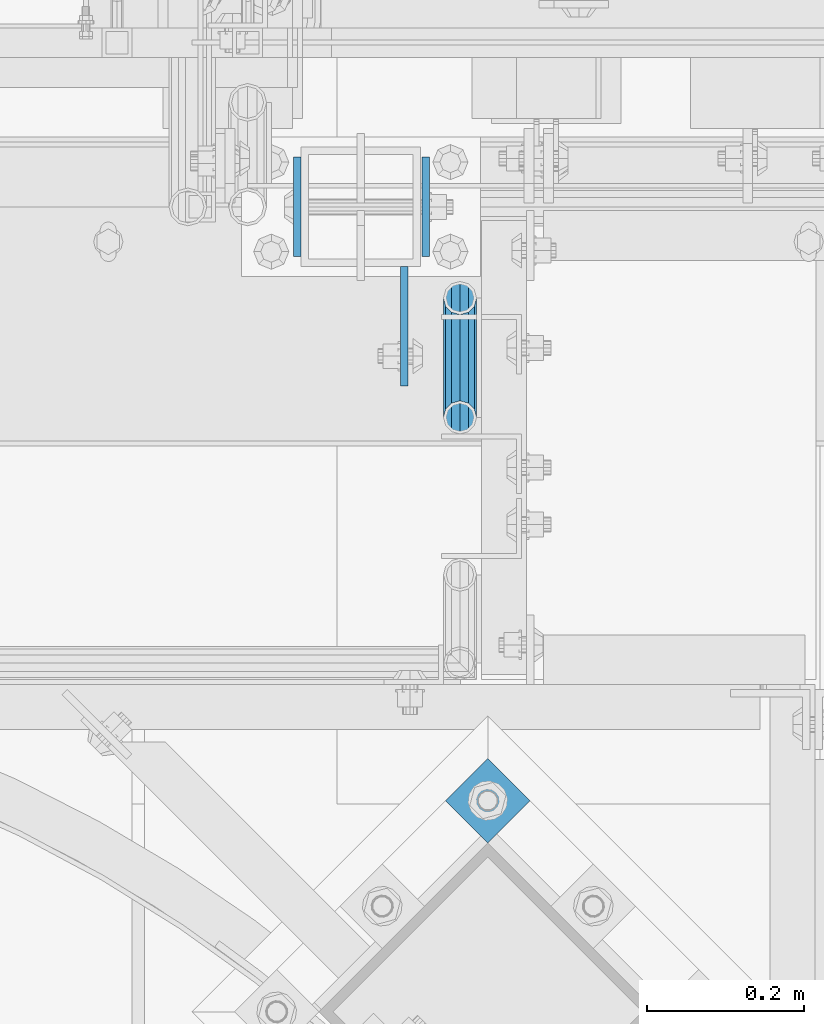
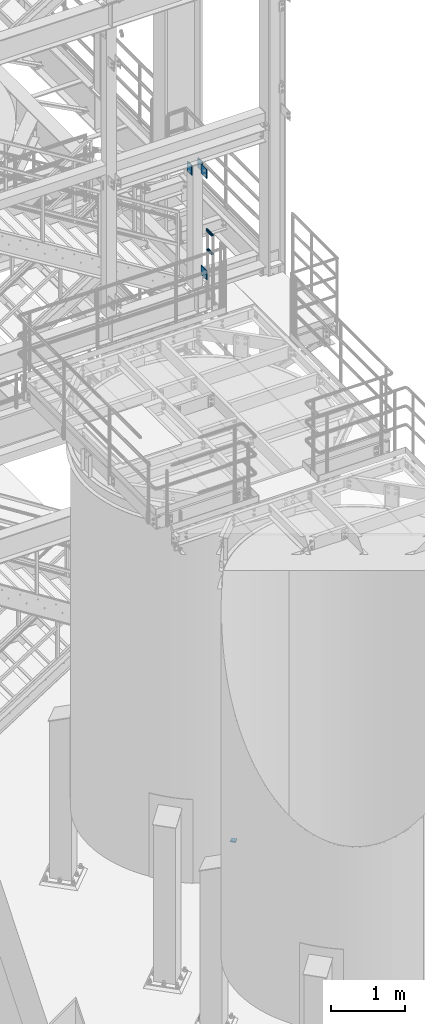
# One storey, part 1151 of 1876: 7 beams, 4 elements without a shape of their own.
"""IFC2X3 building model written with IfcOpenShell, lengths in millimetres."""

from ifc_helpers import new_model, si_unit, frame, origin_with_axes, place, context, subcontext, project, spatial, faceted_brep, material, type_object, element, aggregate, save


model = new_model("IFC2X3")

# Units and contexts
model_context = context("Model", 3, precision=1e-05, world=origin_with_axes())
body_context = subcontext(model_context, "Body", "Model", "MODEL_VIEW")
ifc_project = project(units=[si_unit("LENGTHUNIT", "METRE", prefix="MILLI"), si_unit("AREAUNIT", "SQUARE_METRE"), si_unit("VOLUMEUNIT", "CUBIC_METRE"), si_unit("MASSUNIT", "GRAM", prefix="KILO"), si_unit("TIMEUNIT", "SECOND"), si_unit("PLANEANGLEUNIT", "RADIAN"), si_unit("SOLIDANGLEUNIT", "STERADIAN"), si_unit("THERMODYNAMICTEMPERATUREUNIT", "DEGREE_CELSIUS"), si_unit("LUMINOUSINTENSITYUNIT", "LUMEN")], contexts=[model_context])

# Site, building, storey
site_placement = place(None, origin_with_axes())
site = spatial("IfcSite", under=ifc_project, at=site_placement, CompositionType="ELEMENT")
building_placement = place(site_placement, origin_with_axes())
building = spatial("IfcBuilding", under=site, at=building_placement, Name="Undefined", CompositionType="ELEMENT")
storey_placement = place(building_placement, origin_with_axes())
storey = spatial("IfcBuildingStorey", under=building, at=storey_placement, Name="Undefined", CompositionType="ELEMENT", Elevation=0.0)

# Assembly, beams
assembly_1_placement = place(storey_placement, origin_with_axes())
assembly_1 = element("IfcElementAssembly", 1, at=assembly_1_placement, inside=storey, Name="COLUMN", AssemblyPlace="NOTDEFINED", PredefinedType="RIGID_FRAME")
ifc_material_1 = material(Name="STEEL/A36")
beam_type_1 = type_object("IfcBeamType", PredefinedType="NOTDEFINED")
beam_1_placement = place(assembly_1_placement, frame((6473.8137944527, -7188.2, 8445.5), z_axis=(0.0, 0.0, -1.0), x_axis=(0.0, -1.0, 0.0)))
beam_1 = element("IfcBeam", 2, at=beam_1_placement, type_object=beam_type_1, material=ifc_material_1, Name="PLATE", context=body_context, shape_type="Brep", body=[
    faceted_brep([(0.0, 4.76249999999982, -76.1999999999998), (3.63797880709171e-12, 4.76249999999982, 76.1999969482422), (152.399993896484, 4.76250000000073, 76.1999969482422), (152.4, 4.76249999999982, -76.1999999999998), (3.63797880709171e-12, -4.76249999999982, 76.1999969482422), (152.399993896484, -4.76250000000073, 76.1999969482422), (0.0, -4.76249999999982, -76.1999999999998), (152.4, -4.76249999999982, -76.1999999999998)], [[[0, 1, 2, 3]], [[4, 5, 2, 1]], [[4, 6, 7, 5]], [[6, 0, 3, 7]], [[5, 7, 3, 2]], [[6, 4, 1, 0]]]),
])
beam_2_placement = place(assembly_1_placement, frame((6473.8137944527, -7188.2, 10106.025), z_axis=(0.0, 0.0, -1.0), x_axis=(0.0, -1.0, 0.0)))
beam_2 = element("IfcBeam", 3, at=beam_2_placement, type_object=beam_type_1, material=ifc_material_1, Name="PLATE", context=body_context, shape_type="Brep", body=[
    faceted_brep([(0.0, 4.76249999999982, -76.1999999999998), (3.63797880709171e-12, 4.76249999999982, 76.1999969482422), (152.399993896484, 4.76250000000073, 76.1999969482422), (152.4, 4.76249999999982, -76.1999999999998), (3.63797880709171e-12, -4.76249999999982, 76.1999969482422), (152.399993896484, -4.76250000000073, 76.1999969482422), (0.0, -4.76249999999982, -76.1999999999998), (152.4, -4.76249999999982, -76.1999999999998)], [[[0, 1, 2, 3]], [[4, 5, 2, 1]], [[4, 6, 7, 5]], [[6, 0, 3, 7]], [[5, 7, 3, 2]], [[6, 4, 1, 0]]]),
])
aggregate(assembly_1, [beam_1, beam_2])

assembly_2_placement = place(storey_placement, origin_with_axes())
assembly_2 = element("IfcElementAssembly", 4, at=assembly_2_placement, inside=storey, Name="RAIL", AssemblyPlace="NOTDEFINED", PredefinedType="RIGID_FRAME")
ifc_material_2 = material()
beam_type_2 = type_object("IfcBeamType", Name="PIPE1-1/4STD", PredefinedType="NOTDEFINED")
beam_3_placement = place(assembly_2_placement, frame((6544.818, -7380.684375, 8785.22499999999), z_axis=(0.0, 0.0, -1.0), x_axis=(0.0, 1.0, 0.0)))
beam_3 = element("IfcBeam", 5, at=beam_3_placement, type_object=beam_type_2, material=ifc_material_2, Name="RAIL", ObjectType="PIPE1-1/4STD", context=body_context, shape_type="Brep", body=[
    faceted_brep([(134.227405192596, -10.5410000000002, 18.2575475625836), (134.227405192596, -10.54, 13.4009612267255), (133.751259477646, -8.76299999999992, 15.1779612267255), (131.403220704372, 0.0, 17.5259999999998), (131.403220704372, 0.0, 21.0820000000003), (133.751259477646, 8.76299999999992, 15.1779612267255), (134.227405192596, 10.54, 13.4009612267255), (134.227405192596, 10.5410000000002, 18.2575475625836), (152.483220704372, 21.0820000000003, 0.0), (141.943220704372, 18.2575475625836, 10.5409999999993), (141.943220704372, 18.2575475625836, -10.5409999999993), (138.865366419322, 15.1779612267264, 8.76300000000083), (141.213405192596, 17.5259999999998, 0.0), (138.865366419322, 15.1779612267264, -8.76300000000083), (134.227405192596, 10.54, -13.4009612267255), (134.227405192596, 10.5410000000002, -18.2575475625836), (133.751259477646, 8.76299999999992, -15.1779612267255), (131.403220704372, 0.0, -17.5259999999998), (131.403220704372, 0.0, -21.0820000000003), (134.227405192596, -10.54, -13.4009612267255), (134.227405192596, -10.5410000000002, -18.2575475625836), (133.751259477646, -8.76299999999992, -15.1779612267255), (152.483220704372, -21.0799999999999, 0.0), (141.943220704372, -18.2575475625836, -10.5409999999993), (141.943220704372, -18.2575475625836, 10.5409999999993), (138.865366419322, -15.1779612267264, -8.76300000000083), (141.213405192596, -17.5259999999998, 0.0), (138.865366419322, -15.1779612267264, 8.76300000000083), (10.6232207043722, -18.2575475625836, -10.5409999999993), (18.3390362161481, -10.5410000000002, -18.2575475625836), (0.0832207043722519, 21.0820000000003, 0.0), (10.6232207043722, 18.2575475625836, -10.5409999999993), (10.6232207043722, 18.2575475625836, 10.5409999999993), (18.3390362161481, 10.5410000000002, 18.2575475625836), (21.1632207043722, 0.0, 21.0820000000003), (18.3390362161481, 10.5410000000002, -18.2575475625836), (21.1632207043722, 0.0, -21.0820000000003), (21.1632207043722, 0.0, -17.5259999999998), (18.3390362161481, -10.54, -13.4009612267255), (18.8151819310979, -8.76299999999992, -15.1779612267255), (18.8151819310979, 8.76299999999992, -15.1779612267255), (18.3390362161481, 10.54, -13.4009612267255), (13.7010749894225, 15.1779612267264, -8.76300000000083), (11.3530362161482, 17.5259999999998, 0.0), (13.7010749894225, 15.1779612267264, 8.76300000000083), (18.3390362161481, 10.54, 13.4009612267255), (18.8151819310979, 8.76299999999992, 15.1779612267255), (21.1632207043722, 0.0, 17.5259999999998), (18.8151819310979, -8.76299999999992, 15.1779612267255), (18.3390362161481, -10.54, 13.4009612267255), (18.3390362161481, -10.5410000000002, 18.2575475625836), (10.6232207043722, -18.2575475625836, 10.5409999999993), (0.0832207043722519, -21.0820000000003, 0.0), (13.7010749894225, -15.1779612267264, 8.76300000000083), (11.3530362161482, -17.5259999999998, 0.0), (13.7010749894225, -15.1779612267264, -8.76300000000083)], [[[0, 1, 2, 3, 4]], [[4, 3, 5, 6, 7]], [[8, 9, 10]], [[7, 6, 11, 12, 13, 14, 15, 10, 9]], [[16, 17, 18, 15, 14]], [[19, 20, 18, 17, 21]], [[22, 23, 24]], [[24, 23, 20, 19, 25, 26, 27, 1, 0]], [[28, 29, 20, 23]], [[30, 31, 32]], [[33, 34, 4, 7]], [[32, 33, 7, 9]], [[30, 32, 9, 8]], [[31, 30, 8, 10]], [[35, 31, 10, 15]], [[36, 35, 15, 18]], [[29, 36, 18, 20]], [[37, 36, 29, 38, 39]], [[40, 41, 35, 36, 37]], [[32, 31, 35, 41, 42, 43, 44, 45, 33]], [[33, 45, 46, 47, 34]], [[34, 47, 48, 49, 50]], [[34, 50, 0, 4]], [[50, 51, 24, 0]], [[51, 52, 22, 24]], [[52, 28, 23, 22]], [[51, 28, 52]], [[50, 49, 53, 54, 55, 38, 29, 28, 51]], [[55, 54, 26, 25]], [[21, 39, 38, 55, 25, 19]], [[37, 39, 21, 17]], [[40, 37, 17, 16]], [[42, 41, 40, 16, 14, 13]], [[43, 42, 13, 12]], [[44, 43, 12, 11]], [[5, 46, 45, 44, 11, 6]], [[47, 46, 5, 3]], [[48, 47, 3, 2]], [[53, 49, 48, 2, 1, 27]], [[54, 53, 27, 26]]]),
])
beam_4_placement = place(assembly_2_placement, frame((6544.818, -7386.042187, 9090.02499999999), z_axis=(0.0, 0.0, -1.0), x_axis=(0.0, 1.0, 0.0)))
beam_4 = element("IfcBeam", 6, at=beam_4_placement, type_object=beam_type_2, material=ifc_material_2, Name="RAIL", ObjectType="PIPE1-1/4STD", context=body_context, shape_type="Brep", body=[
    faceted_brep([(5.44103270437245, -17.5259999999998, 0.0), (14.2040327043724, -15.1779612267264, 8.76300000000083), (149.078032704372, -15.1779612267264, 8.76300000000083), (157.841032704372, -17.5259999999998, 0.0), (20.6189939310989, -8.76299999999992, 15.1779612267255), (142.663071477646, -8.76299999999992, 15.1779612267255), (22.9670327043723, 0.0, 17.5259999999998), (140.315032704372, 0.0, 17.5259999999998), (20.6189939310989, 8.76299999999992, 15.1779612267255), (142.663071477646, 8.76299999999992, 15.1779612267255), (14.2040327043724, 15.1779612267264, 8.76300000000083), (149.078032704372, 15.1779612267264, 8.76300000000083), (5.44103270437245, 17.5259999999998, 0.0), (157.841032704372, 17.5259999999998, 0.0), (-3.32196729562747, 15.1779612267264, -8.76300000000083), (166.604032704372, 15.1779612267264, -8.76300000000083), (-9.73692852235399, 8.76299999999992, -15.1779612267255), (173.018993931099, 8.76299999999992, -15.1779612267255), (-12.0849672956274, 0.0, -17.5259999999998), (175.367032704372, 0.0, -17.5259999999998), (-9.73692852235399, -8.76299999999992, -15.1779612267255), (173.018993931099, -8.76299999999992, -15.1779612267255), (-3.32196729562747, -15.1779612267264, -8.76300000000083), (166.604032704372, -15.1779612267264, -8.76300000000083), (5.44103270437245, -21.0820000000003, 0.0), (-5.09996729562772, -18.2575475625836, -10.5409999999993), (168.382032704372, -18.2575475625836, -10.5409999999993), (157.841032704372, -21.0820000000003, 0.0), (-12.8165148582111, -10.5410000000002, -18.2575475625836), (176.098580266956, -10.5410000000002, -18.2575475625836), (-15.6409672956279, 0.0, -21.0820000000003), (178.923032704372, 0.0, -21.0820000000003), (-12.8165148582111, 10.5410000000002, -18.2575475625836), (176.098580266956, 10.5410000000002, -18.2575475625836), (-5.09996729562772, 18.2575475625836, -10.5409999999993), (168.382032704372, 18.2575475625836, -10.5409999999993), (5.44103270437245, 21.0820000000003, 0.0), (157.841032704372, 21.0820000000003, 0.0), (15.9820327043726, 18.2575475625836, 10.5409999999993), (147.300032704372, 18.2575475625836, 10.5409999999993), (23.698580266956, 10.5410000000002, 18.2575475625836), (139.583485141789, 10.5410000000002, 18.2575475625836), (26.5230327043728, 0.0, 21.0820000000003), (136.759032704372, 0.0, 21.0820000000003), (23.698580266956, -10.5410000000002, 18.2575475625836), (139.583485141789, -10.5410000000002, 18.2575475625836), (15.9820327043726, -18.2575475625836, 10.5409999999993), (147.300032704372, -18.2575475625836, 10.5409999999993)], [[[0, 1, 2, 3]], [[1, 4, 5, 2]], [[4, 6, 7, 5]], [[6, 8, 9, 7]], [[8, 10, 11, 9]], [[10, 12, 13, 11]], [[12, 14, 15, 13]], [[14, 16, 17, 15]], [[16, 18, 19, 17]], [[18, 20, 21, 19]], [[20, 22, 23, 21]], [[22, 0, 3, 23]], [[24, 25, 26, 27]], [[25, 28, 29, 26]], [[28, 30, 31, 29]], [[30, 32, 33, 31]], [[32, 34, 35, 33]], [[34, 36, 37, 35]], [[36, 38, 39, 37]], [[38, 40, 41, 39]], [[40, 42, 43, 41]], [[42, 44, 45, 43]], [[44, 46, 47, 45]], [[46, 24, 27, 47]], [[29, 31, 33, 35, 37, 39, 41, 43, 45, 47, 27, 26], [5, 7, 9, 11, 13, 15, 17, 19, 21, 23, 3, 2]], [[46, 44, 42, 40, 38, 36, 34, 32, 30, 28, 25, 24], [22, 20, 18, 16, 14, 12, 10, 8, 6, 4, 1, 0]]]),
])
aggregate(assembly_2, [beam_3, beam_4])

assembly_3_placement = place(storey_placement, origin_with_axes())
assembly_3 = element("IfcElementAssembly", 7, at=assembly_3_placement, inside=storey, Name="BEAM", AssemblyPlace="NOTDEFINED", PredefinedType="RIGID_FRAME")
beam_type_3 = type_object("IfcBeamType", PredefinedType="NOTDEFINED")
beam_5_placement = place(assembly_3_placement, frame((6500.8125, -7048.5, 10112.375), z_axis=(0.0, 0.0, -1.0), x_axis=(0.0, -1.0, 0.0)))
beam_5 = element("IfcBeam", 8, at=beam_5_placement, type_object=beam_type_3, material=ifc_material_1, Name="PLATE", context=body_context, shape_type="Brep", body=[
    faceted_brep([(0.0, 4.76249999999982, -82.5499999999993), (0.0, 4.76249999999982, 82.5499999999993), (127.0, 4.76249999999982, 82.5499999999993), (127.0, 4.76249999999982, -82.5499999999993), (0.0, -4.76249999999982, 82.5499999999993), (127.0, -4.76249999999982, 82.5499999999993), (0.0, -4.76249999999982, -82.5499999999993), (127.0, -4.76249999999982, -82.5499999999993)], [[[0, 1, 2, 3]], [[1, 4, 5, 2]], [[4, 6, 7, 5]], [[6, 0, 3, 7]], [[5, 7, 3, 2]], [[6, 4, 1, 0]]]),
])
beam_6_placement = place(assembly_3_placement, frame((6337.3, -7048.5, 10112.375), z_axis=(0.0, 0.0, -1.0), x_axis=(0.0, -1.0, 0.0)))
beam_6 = element("IfcBeam", 9, at=beam_6_placement, type_object=beam_type_3, material=ifc_material_1, Name="PLATE", context=body_context, shape_type="Brep", body=[
    faceted_brep([(0.0, 4.76249999999982, -82.5499999999993), (0.0, 4.76249999999982, 82.5499999999993), (127.0, 4.76249999999982, 82.5499999999993), (127.0, 4.76249999999982, -82.5499999999993), (0.0, -4.76249999999982, 82.5499999999993), (127.0, -4.76249999999982, 82.5499999999993), (0.0, -4.76249999999982, -82.5499999999993), (127.0, -4.76249999999982, -82.5499999999993)], [[[0, 1, 2, 3]], [[1, 4, 5, 2]], [[4, 6, 7, 5]], [[6, 0, 3, 7]], [[5, 7, 3, 2]], [[6, 4, 1, 0]]]),
])
aggregate(assembly_3, [beam_5, beam_6])

# Assembly, beam
assembly_4_placement = place(storey_placement, origin_with_axes())
assembly_4 = element("IfcElementAssembly", 10, at=assembly_4_placement, inside=storey, Name="TEMPLATE", AssemblyPlace="NOTDEFINED", PredefinedType="RIGID_FRAME")
beam_type_4 = type_object("IfcBeamType", PredefinedType="NOTDEFINED")
beam_7_placement = place(assembly_4_placement, frame((6607.21897365624, -7842.67665714807, -542.925), z_axis=(-0.707106781186548, 0.707106781186547, 0.0), x_axis=(-0.707106781186547, -0.707106781186548, 0.0)))
beam_7 = element("IfcBeam", 11, at=beam_7_placement, type_object=beam_type_4, material=ifc_material_1, Name="PLATE", context=body_context, shape_type="Brep", body=[
    faceted_brep([(0.0, 9.52499999999998, -38.1000000000058), (-9.09494701772928e-13, 9.52499999999998, 38.1000000000076), (76.2000000000762, 9.52499999999998, 38.1000000000058), (76.2000000000762, 9.52499999999998, -38.1000000000058), (-9.09494701772928e-13, -9.52499999999998, 38.1000000000076), (76.2000000000762, -9.52499999999998, 38.1000000000058), (0.0, -9.52499999999998, -38.1000000000058), (76.2000000000762, -9.52499999999998, -38.1000000000058)], [[[0, 1, 2, 3]], [[1, 4, 5, 2]], [[4, 6, 7, 5]], [[6, 0, 3, 7]], [[5, 7, 3, 2]], [[6, 4, 1, 0]]]),
])
aggregate(assembly_4, [beam_7])

save(model, "model.ifc")
